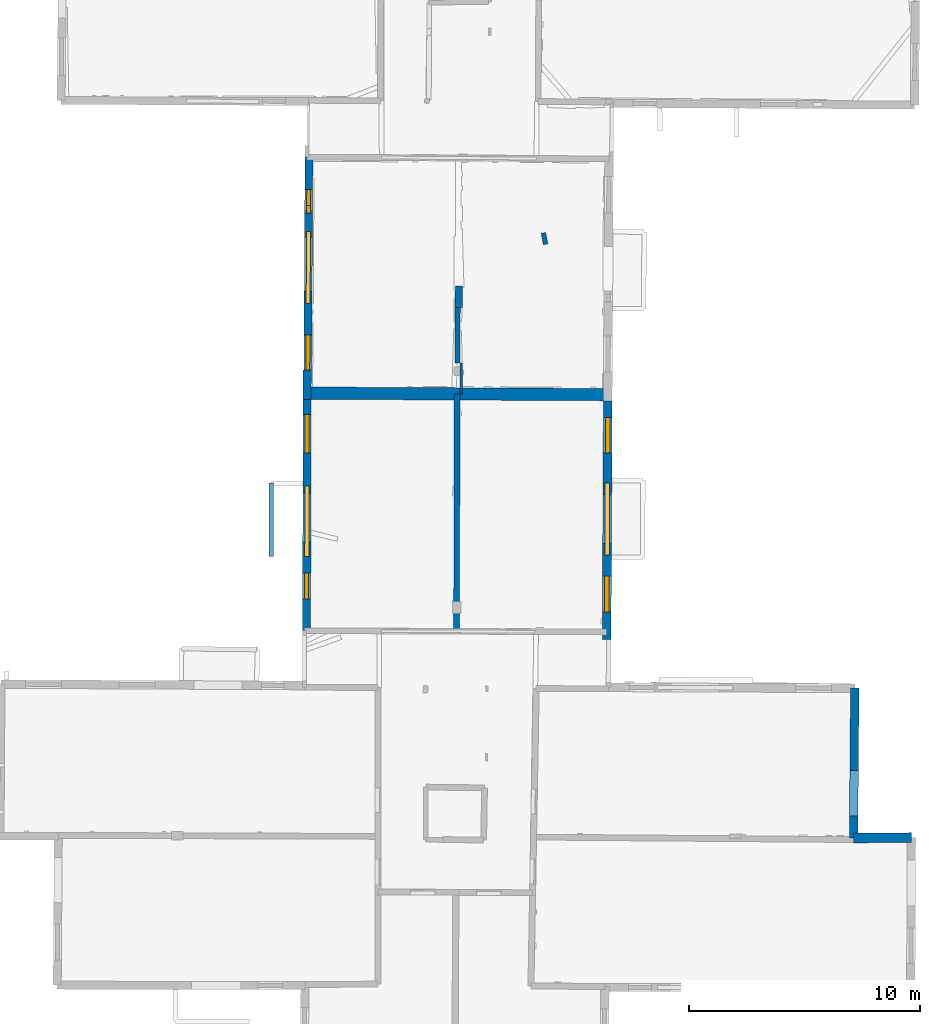
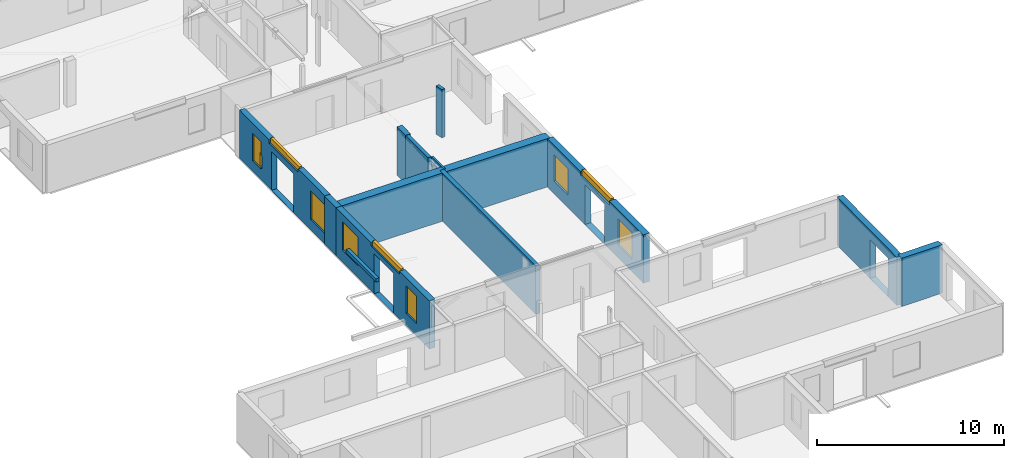
# One storey, part 5 of 14: 14 walls, 10 windows, 14 openings.
"""IFC2X3 building model written with IfcOpenShell, lengths in metres."""

from ifc_helpers import new_model, entity, si_unit, converted_unit, derived_unit, direction, frame, frame_2d, origin, origin_2d_with_axis, place, context, subcontext, project, spatial, polyline, rectangle, outline, extrude, source, transform, mapped, material, layer, layer_set, layer_usage, type_object, type_shapes, element, fill, save


model = new_model("IFC2X3")

# Units and contexts
model_context = context("Model", 3, precision=1e-05, world=origin(), true_north=direction((0.0, 1.0)))
body_context = subcontext(model_context, "Body", "Model", "MODEL_VIEW")
ifc_project = project(units=[si_unit("LENGTHUNIT", "METRE"), si_unit("AREAUNIT", "SQUARE_METRE"), si_unit("VOLUMEUNIT", "CUBIC_METRE"), converted_unit("PLANEANGLEUNIT", "DEGREE", entity("IfcRatioMeasure", 0.0174532925199433), si_unit("PLANEANGLEUNIT", "RADIAN"), dimensions=[0, 0, 0, 0, 0, 0, 0]), si_unit("MASSUNIT", "GRAM", prefix="KILO"), derived_unit("MASSDENSITYUNIT", [(si_unit("MASSUNIT", "GRAM", prefix="KILO"), 1), (si_unit("LENGTHUNIT", "METRE"), -3)]), derived_unit("MOMENTOFINERTIAUNIT", [(si_unit("LENGTHUNIT", "METRE"), 4)]), si_unit("TIMEUNIT", "SECOND"), si_unit("FREQUENCYUNIT", "HERTZ"), si_unit("THERMODYNAMICTEMPERATUREUNIT", "DEGREE_CELSIUS"), derived_unit("THERMALTRANSMITTANCEUNIT", [(si_unit("MASSUNIT", "GRAM", prefix="KILO"), 1), (si_unit("THERMODYNAMICTEMPERATUREUNIT", "KELVIN"), -1), (si_unit("TIMEUNIT", "SECOND"), -3)]), derived_unit("VOLUMETRICFLOWRATEUNIT", [(si_unit("LENGTHUNIT", "METRE"), 3), (si_unit("TIMEUNIT", "SECOND"), -1)]), si_unit("ELECTRICCURRENTUNIT", "AMPERE"), si_unit("ELECTRICVOLTAGEUNIT", "VOLT"), si_unit("POWERUNIT", "WATT"), si_unit("FORCEUNIT", "NEWTON", prefix="KILO"), si_unit("ILLUMINANCEUNIT", "LUX"), si_unit("LUMINOUSFLUXUNIT", "LUMEN"), si_unit("LUMINOUSINTENSITYUNIT", "CANDELA"), derived_unit("USERDEFINED", [(si_unit("MASSUNIT", "GRAM", prefix="KILO"), -1), (si_unit("LENGTHUNIT", "METRE"), -2), (si_unit("TIMEUNIT", "SECOND"), 3), (si_unit("LUMINOUSFLUXUNIT", "LUMEN"), 1)]), derived_unit("LINEARVELOCITYUNIT", [(si_unit("LENGTHUNIT", "METRE"), 1), (si_unit("TIMEUNIT", "SECOND"), -1)]), si_unit("PRESSUREUNIT", "PASCAL"), derived_unit("USERDEFINED", [(si_unit("LENGTHUNIT", "METRE"), -2), (si_unit("MASSUNIT", "GRAM", prefix="KILO"), 1), (si_unit("TIMEUNIT", "SECOND"), -2)]), derived_unit("LINEARFORCEUNIT", [(si_unit("MASSUNIT", "GRAM", prefix="KILO"), 1), (si_unit("LENGTHUNIT", "METRE"), 1), (si_unit("TIMEUNIT", "SECOND"), -2), (si_unit("LENGTHUNIT", "METRE"), -1)]), derived_unit("PLANARFORCEUNIT", [(si_unit("MASSUNIT", "GRAM", prefix="KILO"), 1), (si_unit("LENGTHUNIT", "METRE"), 1), (si_unit("TIMEUNIT", "SECOND"), -2), (si_unit("LENGTHUNIT", "METRE"), -2)])], contexts=[model_context])

# Site, building, storey
placement_1 = place(None, origin())
site = spatial("IfcSite", under=ifc_project, at=placement_1, CompositionType="ELEMENT")
building = spatial("IfcBuilding", under=site, at=placement_1, CompositionType="ELEMENT")
storey_placement = place(placement_1, frame((0.0, 0.0, 8.83152770996094)))
storey = spatial("IfcBuildingStorey", under=building, at=storey_placement, Name="Level 4", CompositionType="ELEMENT", Elevation=8.83152770996094)

# Walls
ifc_material_1 = material(Name="Default wall")
ifc_layer_1 = layer(ifc_material_1, 0.25)
ifc_layer_set_1 = layer_set([ifc_layer_1], Name="wall_thickness_0.2500")
ifc_layer_usage_1 = layer_usage(ifc_layer_set_1, "AXIS2", "POSITIVE", -0.125)
wall_type_1 = type_object("IfcWallType", Name="wall_thickness_0.2500", PredefinedType="STANDARD", material=ifc_layer_set_1)
wall_1_placement = place(storey_placement, frame((6.25137704938162, 38.5592040841499, 0.0), z_axis=(0.0, 0.0, 1.0), x_axis=(-0.00259385507951519, -0.999996635952255, 0.0)))
element("IfcWallStandardCase", 1, at=wall_1_placement, inside=storey, type_object=wall_type_1, material=ifc_layer_usage_1, Name="Wall:412", ObjectType="Wall", context=body_context, shape_type="SweptSolid", body=[
    extrude(outline(polyline([(10.2606603565847, -0.125), (10.2606603565847, 0.125), (0.0, 0.125), (0.0, -0.125), (10.2606603565847, -0.125)])), origin(), (0.0, 0.0, 1.0), 3.14668312072754),
])
ifc_layer_2 = layer(ifc_material_1, 0.349999994039536)
ifc_layer_set_2 = layer_set([ifc_layer_2], Name="wall_thickness_0.3500")
ifc_layer_usage_2 = layer_usage(ifc_layer_set_2, "AXIS2", "POSITIVE", -0.174999997019768)
wall_type_2 = type_object("IfcWallType", Name="wall_thickness_0.3500", PredefinedType="STANDARD", material=ifc_layer_set_2)
wall_2_placement = place(storey_placement, frame((-0.226704717555109, 39.5853526805962, 0.0), z_axis=(0.0, 0.0, 1.0), x_axis=(-0.00264428311052308, -0.999996503877304, 0.0)))
element("IfcWallStandardCase", 2, at=wall_2_placement, inside=storey, type_object=wall_type_2, material=ifc_layer_usage_2, Name="Wall:389", ObjectType="Wall", context=body_context, shape_type="SweptSolid", body=[
    extrude(outline(polyline([(1.25817929498942, -0.174999997019768), (1.25817929498942, 0.174999997019768), (0.0, 0.174999997019768), (0.0, -0.174999997019768), (1.25817929498942, -0.174999997019768)])), origin(), (0.0, 0.0, 1.0), 3.14668312072754),
])

# Wall, openings, windows
wall_3_placement = place(storey_placement, frame((-0.23003169981486, 38.3271777843559, 0.0), z_axis=(0.0, 0.0, 1.0), x_axis=(-0.00264428172284668, -0.999996503880974, 0.0)))
wall_3 = element("IfcWallStandardCase", 3, at=wall_3_placement, inside=storey, type_object=wall_type_2, material=ifc_layer_usage_2, Name="Wall:390", ObjectType="Wall", context=body_context, shape_type="SweptSolid", body=[
    extrude(outline(polyline([(10.0004202470833, -0.174999997019768), (10.0004202470833, 0.174999997019768), (0.0, 0.174999997019768), (0.0, -0.174999997019768), (10.0004202470833, -0.174999997019768)])), origin(), (0.0, 0.0, 1.0), 3.14668312072754),
])
opening_1_placement = place(wall_3_placement, frame((4.05119977164371, -0.174999997019768, 0.00547218322753906)))
element("IfcOpeningElement", 4, at=opening_1_placement, cuts=wall_3, Name="Opening : 2110 x 2600 : 313", ObjectType="Opening", context=body_context, shape_type="SweptSolid", body=[
    extrude(rectangle(XDim=2.11, YDim=2.6, at=frame_2d((1.3, 1.055), x_axis=(0.0, 1.0))), frame((0.0, 0.0, 0.0), z_axis=(0.0, 1.0, 0.0), x_axis=(0.0, 0.0, 1.0)), (0.0, 0.0, 1.0), 0.349999994039536),
])
opening_2_placement = place(wall_3_placement, frame((0.656198888605551, -0.174999997019768, 0.805472373962402)))
opening_2 = element("IfcOpeningElement", 5, at=opening_2_placement, cuts=wall_3, Name="Opening : 1660 x 1835 : 314", ObjectType="Opening", context=body_context, shape_type="SweptSolid", body=[
    extrude(rectangle(XDim=1.66, YDim=1.835, at=frame_2d((0.9175, 0.83), x_axis=(0.0, 1.0))), frame((0.0, 0.0, 0.0), z_axis=(0.0, 1.0, 0.0), x_axis=(0.0, 0.0, 1.0)), (0.0, 0.0, 1.0), 0.349999994039536),
])
opening_3_placement = place(wall_3_placement, frame((3.75763871715652, -0.174999997019768, 2.93047142028809)))
opening_3 = element("IfcOpeningElement", 6, at=opening_3_placement, cuts=wall_3, Name="Opening : 3030 x 310 : 315", ObjectType="Opening", context=body_context, shape_type="SweptSolid", body=[
    extrude(rectangle(XDim=3.03, YDim=0.31, at=frame_2d((0.155, 1.515), x_axis=(0.0, 1.0))), frame((0.0, 0.0, 0.0), z_axis=(0.0, 1.0, 0.0), x_axis=(0.0, 0.0, 1.0)), (0.0, 0.0, 1.0), 0.349999994039536),
])
opening_4_placement = place(wall_3_placement, frame((7.50619842299995, -0.174999997019768, 0.825471878051758)))
opening_4 = element("IfcOpeningElement", 7, at=opening_4_placement, cuts=wall_3, Name="Opening : 1120 x 1780 : 316", ObjectType="Opening", context=body_context, shape_type="SweptSolid", body=[
    extrude(rectangle(XDim=1.12, YDim=1.78, at=frame_2d((0.89, 0.56), x_axis=(0.0, 1.0))), frame((0.0, 0.0, 0.0), z_axis=(0.0, 1.0, 0.0), x_axis=(0.0, 0.0, 1.0)), (0.0, 0.0, 1.0), 0.349999994039536),
])
ifc_material_2 = material(Name="Window Default")
window_style_1 = type_object("IfcWindowStyle", Name="Window : 1660 x 1835mm", ConstructionType="NOTDEFINED", OperationType="NOTDEFINED", ParameterTakesPrecedence=False, Sizeable=False, material=ifc_material_2)
shared_shape_1 = source(origin(), body_context, "Body", "SweptSolid", [
    extrude(rectangle(XDim=0.174999997019768, YDim=1.66, at=origin_2d_with_axis()), frame((0.83, 0.174999997019768, 0.0), z_axis=(0.0, 0.0, 1.0), x_axis=(0.0, 1.0, 0.0)), (0.0, 0.0, 1.0), 1.835),
])
type_shapes(window_style_1, [shared_shape_1])
window_1_placement = place(opening_2_placement, origin())
window_1 = element("IfcWindow", 8, at=window_1_placement, inside=storey, type_object=window_style_1, Name="Window : 1660 x 1835mm : 168", ObjectType="Window : 1660 x 1835mm", OverallHeight=1.835, OverallWidth=1.66, context=body_context, shape_type="MappedRepresentation", body=[
    mapped(shared_shape_1, transform((0.0, 0.0, 0.0), scale=1.0)),
])
fill(opening_2, window_1)
window_style_2 = type_object("IfcWindowStyle", Name="Window : 3030 x 310mm", ConstructionType="NOTDEFINED", OperationType="NOTDEFINED", ParameterTakesPrecedence=False, Sizeable=False, material=ifc_material_2)
shared_shape_2 = source(origin(), body_context, "Body", "SweptSolid", [
    extrude(rectangle(XDim=0.174999997019768, YDim=3.03, at=origin_2d_with_axis()), frame((1.515, 0.174999997019768, 0.0), z_axis=(0.0, 0.0, 1.0), x_axis=(0.0, 1.0, 0.0)), (0.0, 0.0, 1.0), 0.31),
])
type_shapes(window_style_2, [shared_shape_2])
window_2_placement = place(opening_3_placement, origin())
window_2 = element("IfcWindow", 9, at=window_2_placement, inside=storey, type_object=window_style_2, Name="Window : 3030 x 310mm : 169", ObjectType="Window : 3030 x 310mm", OverallHeight=0.31, OverallWidth=3.03, context=body_context, shape_type="MappedRepresentation", body=[
    mapped(shared_shape_2, transform((0.0, 0.0, 0.0), scale=1.0)),
])
fill(opening_3, window_2)
window_style_3 = type_object("IfcWindowStyle", Name="Window : 1120 x 1780mm", ConstructionType="NOTDEFINED", OperationType="NOTDEFINED", ParameterTakesPrecedence=False, Sizeable=False, material=ifc_material_2)
shared_shape_3 = source(origin(), body_context, "Body", "SweptSolid", [
    extrude(rectangle(XDim=0.174999997019768, YDim=1.12, at=origin_2d_with_axis()), frame((0.56, 0.174999997019768, 0.0), z_axis=(0.0, 0.0, 1.0), x_axis=(0.0, 1.0, 0.0)), (0.0, 0.0, 1.0), 1.78),
])
type_shapes(window_style_3, [shared_shape_3])
window_3_placement = place(opening_4_placement, origin())
window_3 = element("IfcWindow", 10, at=window_3_placement, inside=storey, type_object=window_style_3, Name="Window : 1120 x 1780mm : 170", ObjectType="Window : 1120 x 1780mm", OverallHeight=1.78, OverallWidth=1.12, context=body_context, shape_type="MappedRepresentation", body=[
    mapped(shared_shape_3, transform((0.0, 0.0, 0.0), scale=1.0)),
])
fill(opening_4, window_3)

# Walls
ifc_layer_3 = layer(ifc_material_1, 0.2)
ifc_layer_set_3 = layer_set([ifc_layer_3], Name="wall_thickness_0.2000")
ifc_layer_usage_3 = layer_usage(ifc_layer_set_3, "AXIS2", "POSITIVE", -0.1)
wall_type_3 = type_object("IfcWallType", Name="wall_thickness_0.2000", PredefinedType="STANDARD", material=ifc_layer_set_3)
wall_4_placement = place(storey_placement, frame((9.9778537011572, 45.517375815951, 0.0), z_axis=(0.0, 0.0, 1.0), x_axis=(0.190275788815913, -0.981730678032668, 0.0)))
element("IfcWallStandardCase", 11, at=wall_4_placement, inside=storey, type_object=wall_type_3, material=ifc_layer_usage_3, Name="Wall:437", ObjectType="Wall", context=body_context, shape_type="SweptSolid", body=[
    extrude(outline(polyline([(0.499998432393384, -0.1), (0.499998432393384, 0.1), (0.0, 0.1), (0.0, -0.1), (0.499998432393384, -0.1)])), origin(), (0.0, 0.0, 1.0), 3.14668312072754),
])
placement_2 = place(placement_1, frame((0.0, 0.0, 11.7639999389648)))
wall_5_placement = place(placement_2, frame((-1.78366930186404, 34.7042167644067, 0.0), z_axis=(0.0, 0.0, 1.0), x_axis=(0.00170898613008799, -0.999998539682137, 0.0)))
element("IfcWallStandardCase", 12, at=wall_5_placement, inside=storey, type_object=wall_type_3, material=ifc_layer_usage_3, Name="Wall:481", ObjectType="Wall", context=body_context, shape_type="SweptSolid", body=[
    extrude(outline(polyline([(3.17689405883081, -0.1), (3.17689405883081, 0.1), (0.0, 0.1), (0.0, -0.1), (3.17689405883081, -0.1)])), origin(), (0.0, 0.0, 1.0), 0.214210891723633),
])

# Wall, openings, windows
ifc_layer_4 = layer(ifc_material_1, 0.379999995231628)
ifc_layer_set_4 = layer_set([ifc_layer_4], Name="wall_thickness_0.3800")
ifc_layer_usage_4 = layer_usage(ifc_layer_set_4, "AXIS2", "POSITIVE", -0.189999997615814)
wall_type_4 = type_object("IfcWallType", Name="wall_thickness_0.3800", PredefinedType="STANDARD", material=ifc_layer_set_4)
wall_6_placement = place(storey_placement, frame((12.7611702525799, 38.261074578555, 0.0), z_axis=(0.0, 0.0, 1.0), x_axis=(-0.0048013676829294, -0.999988473367755, 0.0)))
wall_6 = element("IfcWallStandardCase", 13, at=wall_6_placement, inside=storey, type_object=wall_type_4, material=ifc_layer_usage_4, Name="Wall:463", ObjectType="Wall", context=body_context, shape_type="SweptSolid", body=[
    extrude(outline(polyline([(10.3207824160118, -0.189999997615814), (10.3207824160118, 0.189999997615814), (0.0, 0.189999997615814), (0.0, -0.189999997615814), (10.3207824160118, -0.189999997615814)])), origin(), (0.0, 0.0, 1.0), 3.14668312072754),
])
opening_5_placement = place(wall_6_placement, frame((4.04745186024047, -0.189999997615814, 0.00547218322753906)))
element("IfcOpeningElement", 14, at=opening_5_placement, cuts=wall_6, Name="Opening : 2125 x 2615 : 359", ObjectType="Opening", context=body_context, shape_type="SweptSolid", body=[
    extrude(rectangle(XDim=2.125, YDim=2.615, at=frame_2d((1.3075, 1.0625), x_axis=(0.0, 1.0))), frame((0.0, 0.0, 0.0), z_axis=(0.0, 1.0, 0.0), x_axis=(0.0, 0.0, 1.0)), (0.0, 0.0, 1.0), 0.379999995231628),
])
opening_6_placement = place(wall_6_placement, frame((3.55429737136383, -0.189999997615814, 2.88547229766846)))
opening_6 = element("IfcOpeningElement", 15, at=opening_6_placement, cuts=wall_6, Name="Opening : 3110 x 355 : 360", ObjectType="Opening", context=body_context, shape_type="SweptSolid", body=[
    extrude(rectangle(XDim=3.11, YDim=0.355, at=frame_2d((0.1775, 1.555), x_axis=(0.0, 1.0))), frame((0.0, 0.0, 0.0), z_axis=(0.0, 1.0, 0.0), x_axis=(0.0, 0.0, 1.0)), (0.0, 0.0, 1.0), 0.379999995231628),
])
opening_7_placement = place(wall_6_placement, frame((7.57644990423556, -0.189999997615814, 0.82047176361084)))
opening_7 = element("IfcOpeningElement", 16, at=opening_7_placement, cuts=wall_6, Name="Opening : 1550 x 1740 : 361", ObjectType="Opening", context=body_context, shape_type="SweptSolid", body=[
    extrude(rectangle(XDim=1.55, YDim=1.74, at=frame_2d((0.87, 0.775), x_axis=(0.0, 1.0))), frame((0.0, 0.0, 0.0), z_axis=(0.0, 1.0, 0.0), x_axis=(0.0, 0.0, 1.0)), (0.0, 0.0, 1.0), 0.379999995231628),
])
opening_8_placement = place(wall_6_placement, frame((0.726448771232858, -0.189999997615814, 0.82047176361084)))
opening_8 = element("IfcOpeningElement", 17, at=opening_8_placement, cuts=wall_6, Name="Opening : 1520 x 1705 : 362", ObjectType="Opening", context=body_context, shape_type="SweptSolid", body=[
    extrude(rectangle(XDim=1.52, YDim=1.705, at=frame_2d((0.8525, 0.76), x_axis=(0.0, 1.0))), frame((0.0, 0.0, 0.0), z_axis=(0.0, 1.0, 0.0), x_axis=(0.0, 0.0, 1.0)), (0.0, 0.0, 1.0), 0.379999995231628),
])
window_style_4 = type_object("IfcWindowStyle", Name="Window : 1550 x 1740mm", ConstructionType="NOTDEFINED", OperationType="NOTDEFINED", ParameterTakesPrecedence=False, Sizeable=False, material=ifc_material_2)
shared_shape_4 = source(origin(), body_context, "Body", "SweptSolid", [
    extrude(rectangle(XDim=0.189999997615814, YDim=1.55, at=origin_2d_with_axis()), frame((0.775, 0.189999997615814, 0.0), z_axis=(0.0, 0.0, 1.0), x_axis=(0.0, 1.0, 0.0)), (0.0, 0.0, 1.0), 1.74),
])
type_shapes(window_style_4, [shared_shape_4])
window_4_placement = place(opening_7_placement, origin())
window_4 = element("IfcWindow", 18, at=window_4_placement, inside=storey, type_object=window_style_4, Name="Window : 1550 x 1740mm : 196", ObjectType="Window : 1550 x 1740mm", OverallHeight=1.74, OverallWidth=1.55, context=body_context, shape_type="MappedRepresentation", body=[
    mapped(shared_shape_4, transform((0.0, 0.0, 0.0), scale=1.0)),
])
fill(opening_7, window_4)
window_style_5 = type_object("IfcWindowStyle", Name="Window : 3110 x 355mm", ConstructionType="NOTDEFINED", OperationType="NOTDEFINED", ParameterTakesPrecedence=False, Sizeable=False, material=ifc_material_2)
shared_shape_5 = source(origin(), body_context, "Body", "SweptSolid", [
    extrude(rectangle(XDim=0.189999997615814, YDim=3.11, at=origin_2d_with_axis()), frame((1.555, 0.189999997615814, 0.0), z_axis=(0.0, 0.0, 1.0), x_axis=(0.0, 1.0, 0.0)), (0.0, 0.0, 1.0), 0.355),
])
type_shapes(window_style_5, [shared_shape_5])
window_5_placement = place(opening_6_placement, origin())
window_5 = element("IfcWindow", 19, at=window_5_placement, inside=storey, type_object=window_style_5, Name="Window : 3110 x 355mm : 195", ObjectType="Window : 3110 x 355mm", OverallHeight=0.355, OverallWidth=3.11, context=body_context, shape_type="MappedRepresentation", body=[
    mapped(shared_shape_5, transform((0.0, 0.0, 0.0), scale=1.0)),
])
fill(opening_6, window_5)
window_style_6 = type_object("IfcWindowStyle", Name="Window : 1520 x 1705mm", ConstructionType="NOTDEFINED", OperationType="NOTDEFINED", ParameterTakesPrecedence=False, Sizeable=False, material=ifc_material_2)
shared_shape_6 = source(origin(), body_context, "Body", "SweptSolid", [
    extrude(rectangle(XDim=0.189999997615814, YDim=1.52, at=origin_2d_with_axis()), frame((0.76, 0.189999997615814, 0.0), z_axis=(0.0, 0.0, 1.0), x_axis=(0.0, 1.0, 0.0)), (0.0, 0.0, 1.0), 1.705),
])
type_shapes(window_style_6, [shared_shape_6])
window_6_placement = place(opening_8_placement, origin())
window_6 = element("IfcWindow", 20, at=window_6_placement, inside=storey, type_object=window_style_6, Name="Window : 1520 x 1705mm : 197", ObjectType="Window : 1520 x 1705mm", OverallHeight=1.705, OverallWidth=1.52, context=body_context, shape_type="MappedRepresentation", body=[
    mapped(shared_shape_6, transform((0.0, 0.0, 0.0), scale=1.0)),
])
fill(opening_8, window_6)

ifc_layer_5 = layer(ifc_material_1, 0.340000003576279)
ifc_layer_set_5 = layer_set([ifc_layer_5], Name="wall_thickness_0.3400")
ifc_layer_usage_5 = layer_usage(ifc_layer_set_5, "AXIS2", "POSITIVE", -0.170000001788139)
wall_type_5 = type_object("IfcWallType", Name="wall_thickness_0.3400", PredefinedType="STANDARD", material=ifc_layer_set_5)
wall_7_placement = place(storey_placement, frame((-0.153883172054511, 48.7889196604976, 0.0), z_axis=(0.0, 0.0, 1.0), x_axis=(-0.00555251228895166, -0.999984584684825, 0.0)))
wall_7 = element("IfcWallStandardCase", 21, at=wall_7_placement, inside=storey, type_object=wall_type_5, material=ifc_layer_usage_5, Name="Wall:495", ObjectType="Wall", context=body_context, shape_type="SweptSolid", body=[
    extrude(outline(polyline([(9.20426252259407, -0.170000001788139), (9.20426252259407, 0.170000001788139), (0.0, 0.170000001788139), (0.0, -0.170000001788139), (9.20426252259407, -0.170000001788139)])), origin(), (0.0, 0.0, 1.0), 3.14668312072754),
])
opening_9_placement = place(wall_7_placement, frame((3.45926276892288, -0.170000001788139, 0.00547218322753906)))
element("IfcOpeningElement", 22, at=opening_9_placement, cuts=wall_7, Name="Opening : 2345 x 2525 : 382", ObjectType="Opening", context=body_context, shape_type="SweptSolid", body=[
    extrude(rectangle(XDim=2.345, YDim=2.525, at=frame_2d((1.2625, 1.1725), x_axis=(0.0, 1.0))), frame((0.0, 0.0, 0.0), z_axis=(0.0, 1.0, 0.0), x_axis=(0.0, 0.0, 1.0)), (0.0, 0.0, 1.0), 0.340000003576279),
])
opening_10_placement = place(wall_7_placement, frame((1.40426511750016, -0.170000001788139, 0.69547176361084)))
opening_10 = element("IfcOpeningElement", 23, at=opening_10_placement, cuts=wall_7, Name="Opening : 920 x 1790 : 383", ObjectType="Opening", context=body_context, shape_type="SweptSolid", body=[
    extrude(rectangle(XDim=0.92, YDim=1.79, at=frame_2d((0.895, 0.46), x_axis=(0.0, 1.0))), frame((0.0, 0.0, 0.0), z_axis=(0.0, 1.0, 0.0), x_axis=(0.0, 0.0, 1.0)), (0.0, 0.0, 1.0), 0.340000003576279),
])
opening_11_placement = place(wall_7_placement, frame((2.08848739605725, -0.170000001788139, 0.788473129272461)))
opening_11 = element("IfcOpeningElement", 24, at=opening_11_placement, cuts=wall_7, Name="Opening : 325 x 820 : 384", ObjectType="Opening", context=body_context, shape_type="SweptSolid", body=[
    extrude(rectangle(XDim=0.325, YDim=0.82, at=frame_2d((0.41, 0.1625), x_axis=(0.0, 1.0))), frame((0.0, 0.0, 0.0), z_axis=(0.0, 1.0, 0.0), x_axis=(0.0, 0.0, 1.0)), (0.0, 0.0, 1.0), 0.340000003576279),
])
opening_12_placement = place(wall_7_placement, frame((3.2042615845195, -0.170000001788139, 2.92047214508057)))
opening_12 = element("IfcOpeningElement", 25, at=opening_12_placement, cuts=wall_7, Name="Opening : 3110 x 320 : 385", ObjectType="Opening", context=body_context, shape_type="SweptSolid", body=[
    extrude(rectangle(XDim=3.11, YDim=0.32, at=frame_2d((0.16, 1.555), x_axis=(0.0, 1.0))), frame((0.0, 0.0, 0.0), z_axis=(0.0, 1.0, 0.0), x_axis=(0.0, 0.0, 1.0)), (0.0, 0.0, 1.0), 0.340000003576279),
])
opening_13_placement = place(wall_7_placement, frame((7.67926419253096, -0.170000001788139, 0.69547176361084)))
opening_13 = element("IfcOpeningElement", 26, at=opening_13_placement, cuts=wall_7, Name="Opening : 1525 x 1850 : 386", ObjectType="Opening", context=body_context, shape_type="SweptSolid", body=[
    extrude(rectangle(XDim=1.525, YDim=1.85, at=frame_2d((0.925, 0.7625), x_axis=(0.0, 1.0))), frame((0.0, 0.0, 0.0), z_axis=(0.0, 1.0, 0.0), x_axis=(0.0, 0.0, 1.0)), (0.0, 0.0, 1.0), 0.340000003576279),
])
window_style_7 = type_object("IfcWindowStyle", Name="Window : 920 x 1790mm", ConstructionType="NOTDEFINED", OperationType="NOTDEFINED", ParameterTakesPrecedence=False, Sizeable=False, material=ifc_material_2)
shared_shape_7 = source(origin(), body_context, "Body", "SweptSolid", [
    extrude(rectangle(XDim=0.170000001788139, YDim=0.92, at=origin_2d_with_axis()), frame((0.46, 0.170000001788139, 0.0), z_axis=(0.0, 0.0, 1.0), x_axis=(0.0, 1.0, 0.0)), (0.0, 0.0, 1.0), 1.79),
])
type_shapes(window_style_7, [shared_shape_7])
window_7_placement = place(opening_10_placement, origin())
window_7 = element("IfcWindow", 27, at=window_7_placement, inside=storey, type_object=window_style_7, Name="Window : 920 x 1790mm : 208", ObjectType="Window : 920 x 1790mm", OverallHeight=1.79, OverallWidth=0.92, context=body_context, shape_type="MappedRepresentation", body=[
    mapped(shared_shape_7, transform((0.0, 0.0, 0.0), scale=1.0)),
])
fill(opening_10, window_7)
window_style_8 = type_object("IfcWindowStyle", Name="Window : 325 x 820mm", ConstructionType="NOTDEFINED", OperationType="NOTDEFINED", ParameterTakesPrecedence=False, Sizeable=False, material=ifc_material_2)
shared_shape_8 = source(origin(), body_context, "Body", "SweptSolid", [
    extrude(rectangle(XDim=0.170000001788139, YDim=0.325, at=origin_2d_with_axis()), frame((0.1625, 0.170000001788139, 0.0), z_axis=(0.0, 0.0, 1.0), x_axis=(0.0, 1.0, 0.0)), (0.0, 0.0, 1.0), 0.82),
])
type_shapes(window_style_8, [shared_shape_8])
window_8_placement = place(opening_11_placement, origin())
window_8 = element("IfcWindow", 28, at=window_8_placement, inside=storey, type_object=window_style_8, Name="Window : 325 x 820mm : 209", ObjectType="Window : 325 x 820mm", OverallHeight=0.82, OverallWidth=0.325, context=body_context, shape_type="MappedRepresentation", body=[
    mapped(shared_shape_8, transform((0.0, 0.0, 0.0), scale=1.0)),
])
fill(opening_11, window_8)
window_style_9 = type_object("IfcWindowStyle", Name="Window : 3110 x 320mm", ConstructionType="NOTDEFINED", OperationType="NOTDEFINED", ParameterTakesPrecedence=False, Sizeable=False, material=ifc_material_2)
shared_shape_9 = source(origin(), body_context, "Body", "SweptSolid", [
    extrude(rectangle(XDim=0.170000001788139, YDim=3.11, at=origin_2d_with_axis()), frame((1.555, 0.170000001788139, 0.0), z_axis=(0.0, 0.0, 1.0), x_axis=(0.0, 1.0, 0.0)), (0.0, 0.0, 1.0), 0.32),
])
type_shapes(window_style_9, [shared_shape_9])
window_9_placement = place(opening_12_placement, origin())
window_9 = element("IfcWindow", 29, at=window_9_placement, inside=storey, type_object=window_style_9, Name="Window : 3110 x 320mm : 210", ObjectType="Window : 3110 x 320mm", OverallHeight=0.32, OverallWidth=3.11, context=body_context, shape_type="MappedRepresentation", body=[
    mapped(shared_shape_9, transform((0.0, 0.0, 0.0), scale=1.0)),
])
fill(opening_12, window_9)
window_style_10 = type_object("IfcWindowStyle", Name="Window : 1525 x 1850mm", ConstructionType="NOTDEFINED", OperationType="NOTDEFINED", ParameterTakesPrecedence=False, Sizeable=False, material=ifc_material_2)
shared_shape_10 = source(origin(), body_context, "Body", "SweptSolid", [
    extrude(rectangle(XDim=0.170000001788139, YDim=1.525, at=origin_2d_with_axis()), frame((0.7625, 0.170000001788139, 0.0), z_axis=(0.0, 0.0, 1.0), x_axis=(0.0, 1.0, 0.0)), (0.0, 0.0, 1.0), 1.85),
])
type_shapes(window_style_10, [shared_shape_10])
window_10_placement = place(opening_13_placement, origin())
window_10 = element("IfcWindow", 30, at=window_10_placement, inside=storey, type_object=window_style_10, Name="Window : 1525 x 1850mm : 211", ObjectType="Window : 1525 x 1850mm", OverallHeight=1.85, OverallWidth=1.525, context=body_context, shape_type="MappedRepresentation", body=[
    mapped(shared_shape_10, transform((0.0, 0.0, 0.0), scale=1.0)),
])
fill(opening_13, window_10)

# Wall, opening
ifc_layer_6 = layer(ifc_material_1, 0.370000004768372)
ifc_layer_set_6 = layer_set([ifc_layer_6], Name="wall_thickness_0.3700")
ifc_layer_usage_6 = layer_usage(ifc_layer_set_6, "AXIS2", "POSITIVE", -0.185000002384186)
wall_type_6 = type_object("IfcWallType", Name="wall_thickness_0.3700", PredefinedType="STANDARD", material=ifc_layer_set_6)
wall_8_placement = place(storey_placement, frame((23.4341372734612, 25.8408513688769, 0.0), z_axis=(0.0, 0.0, 1.0), x_axis=(-0.00817914615856783, -0.999966550224615, 0.0)))
wall_8 = element("IfcWallStandardCase", 31, at=wall_8_placement, inside=storey, type_object=wall_type_6, material=ifc_layer_usage_6, Name="Wall:489", ObjectType="Wall", context=body_context, shape_type="SweptSolid", body=[
    extrude(outline(polyline([(6.47283652530385, -0.185000002384186), (6.47283652530385, 0.185000002384186), (0.0, 0.185000002384186), (0.0, -0.185000002384186), (6.47283652530385, -0.185000002384186)])), origin(), (0.0, 0.0, 1.0), 3.14668312072754),
])
opening_14_placement = place(wall_8_placement, frame((3.55781052648915, -0.185000002384186, 0.00547218322753906)))
element("IfcOpeningElement", 32, at=opening_14_placement, cuts=wall_8, Name="Opening : 1970 x 2510 : 379", ObjectType="Opening", context=body_context, shape_type="SweptSolid", body=[
    extrude(rectangle(XDim=1.97, YDim=2.51, at=frame_2d((1.255, 0.985), x_axis=(0.0, 1.0))), frame((0.0, 0.0, 0.0), z_axis=(0.0, 1.0, 0.0), x_axis=(0.0, 0.0, 1.0)), (0.0, 0.0, 1.0), 0.370000004768372),
])

# Walls
ifc_layer_7 = layer(ifc_material_1, 0.319999992847443)
ifc_layer_set_7 = layer_set([ifc_layer_7], Name="wall_thickness_0.3200")
ifc_layer_usage_7 = layer_usage(ifc_layer_set_7, "AXIS2", "POSITIVE", -0.159999996423721)
wall_type_7 = type_object("IfcWallType", Name="wall_thickness_0.3200", PredefinedType="STANDARD", material=ifc_layer_set_7)
wall_9_placement = place(storey_placement, frame((6.33184605714149, 43.2290206598161, 0.0), z_axis=(0.0, 0.0, 1.0), x_axis=(-0.0100466385721786, -0.999949531253153, 0.0)))
element("IfcWallStandardCase", 33, at=wall_9_placement, inside=storey, type_object=wall_type_7, material=ifc_layer_usage_7, Name="Wall:373", ObjectType="Wall", context=body_context, shape_type="SweptSolid", body=[
    extrude(outline(polyline([(0.930546994058251, -0.159999996423721), (0.930546994058251, 0.159999996423721), (0.0, 0.159999996423721), (0.0, -0.159999996423721), (0.930546994058251, -0.159999996423721)])), origin(), (0.0, 0.0, 1.0), 3.14668312072754),
])
ifc_layer_8 = layer(ifc_material_1, 0.219999998807907)
ifc_layer_set_8 = layer_set([ifc_layer_8], Name="wall_thickness_0.2200")
ifc_layer_usage_8 = layer_usage(ifc_layer_set_8, "AXIS2", "POSITIVE", -0.109999999403954)
wall_type_8 = type_object("IfcWallType", Name="wall_thickness_0.2200", PredefinedType="STANDARD", material=ifc_layer_set_8)
wall_10_placement = place(storey_placement, frame((6.27607348312058, 42.2974502377704, 0.0), z_axis=(0.0, 0.0, 1.0), x_axis=(-0.00259383153601416, -0.999996636013323, 0.0)))
element("IfcWallStandardCase", 34, at=wall_10_placement, inside=storey, type_object=wall_type_8, material=ifc_layer_usage_8, Name="Wall:410", ObjectType="Wall", context=body_context, shape_type="SweptSolid", body=[
    extrude(outline(polyline([(2.39445156686606, -0.109999999403954), (2.39445156686606, 0.109999999403954), (0.0, 0.109999999403954), (0.0, -0.109999999403954), (2.39445156686606, -0.109999999403954)])), origin(), (0.0, 0.0, 1.0), 3.14668312072754),
])
ifc_layer_9 = layer(ifc_material_1, 0.100000001490116)
ifc_layer_set_9 = layer_set([ifc_layer_9], Name="wall_thickness_0.1000")
ifc_layer_usage_9 = layer_usage(ifc_layer_set_9, "AXIS2", "POSITIVE", -0.0500000007450581)
wall_type_9 = type_object("IfcWallType", Name="wall_thickness_0.1000", PredefinedType="STANDARD", material=ifc_layer_set_9)
wall_11_placement = place(storey_placement, frame((6.42986166419195, 39.9025917061969, 0.0), z_axis=(0.0, 0.0, 1.0), x_axis=(-0.00259403373614825, -0.999996635488828, 0.0)))
element("IfcWallStandardCase", 35, at=wall_11_placement, inside=storey, type_object=wall_type_9, material=ifc_layer_usage_9, Name="Wall:411", ObjectType="Wall", context=body_context, shape_type="SweptSolid", body=[
    extrude(outline(polyline([(1.34428095107093, -0.0500000007450581), (1.34428095107093, 0.0500000007450581), (0.0, 0.0500000007450581), (0.0, -0.0500000007450581), (1.34428095107093, -0.0500000007450581)])), origin(), (0.0, 0.0, 1.0), 3.14668312072754),
])
ifc_layer_10 = layer(ifc_material_1, 0.419999986886978)
ifc_layer_set_10 = layer_set([ifc_layer_10], Name="wall_thickness_0.4200")
ifc_layer_usage_10 = layer_usage(ifc_layer_set_10, "AXIS2", "POSITIVE", -0.209999993443489)
wall_type_10 = type_object("IfcWallType", Name="wall_thickness_0.4200", PredefinedType="STANDARD", material=ifc_layer_set_10)
wall_12_placement = place(storey_placement, frame((23.3811904928517, 19.3682351887957, 0.0), z_axis=(0.0, 0.0, 1.0), x_axis=(0.999974872453564, 0.00708903812076568, 0.0)))
element("IfcWallStandardCase", 36, at=wall_12_placement, inside=storey, type_object=wall_type_10, material=ifc_layer_usage_10, Name="Wall:420", ObjectType="Wall", context=body_context, shape_type="SweptSolid", body=[
    extrude(outline(polyline([(2.50383565084229, -0.209999993443489), (2.50383565084229, 0.209999993443489), (0.0, 0.209999993443489), (0.0, -0.209999993443489), (2.50383565084229, -0.209999993443489)])), origin(), (0.0, 0.0, 1.0), 3.14668312072754),
])
ifc_layer_11 = layer(ifc_material_1, 0.529999971389771)
ifc_layer_set_11 = layer_set([ifc_layer_11], Name="wall_thickness_0.5300")
ifc_layer_usage_11 = layer_usage(ifc_layer_set_11, "AXIS2", "POSITIVE", -0.264999985694885)
wall_type_11 = type_object("IfcWallType", Name="wall_thickness_0.5300", PredefinedType="STANDARD", material=ifc_layer_set_11)
wall_13_placement = place(storey_placement, frame((-0.229333989392349, 38.5921793249979, 0.0), z_axis=(0.0, 0.0, 1.0), x_axis=(0.999987055264478, -0.00508815324827529, 0.0)))
element("IfcWallStandardCase", 37, at=wall_13_placement, inside=storey, type_object=wall_type_11, material=ifc_layer_usage_11, Name="Wall:452", ObjectType="Wall", context=body_context, shape_type="SweptSolid", body=[
    extrude(outline(polyline([(6.6057950630349, -0.264999985694885), (6.6057950630349, 0.264999985694885), (0.0, 0.264999985694885), (0.0, -0.264999985694885), (6.6057950630349, -0.264999985694885)])), origin(), (0.0, 0.0, 1.0), 3.14668312072754),
])
wall_14_placement = place(storey_placement, frame((6.37637556337254, 38.5585680273905, 0.0), z_axis=(0.0, 0.0, 1.0), x_axis=(0.999987052329357, -0.00508873006199565, 0.0)))
element("IfcWallStandardCase", 38, at=wall_14_placement, inside=storey, type_object=wall_type_11, material=ifc_layer_usage_11, Name="Wall:453", ObjectType="Wall", context=body_context, shape_type="SweptSolid", body=[
    extrude(outline(polyline([(6.38615246042642, -0.264999985694885), (6.38615246042642, 0.264999985694885), (0.0, 0.264999985694885), (0.0, -0.264999985694885), (6.38615246042642, -0.264999985694885)])), origin(), (0.0, 0.0, 1.0), 3.14668312072754),
])

save(model, "model.ifc")
